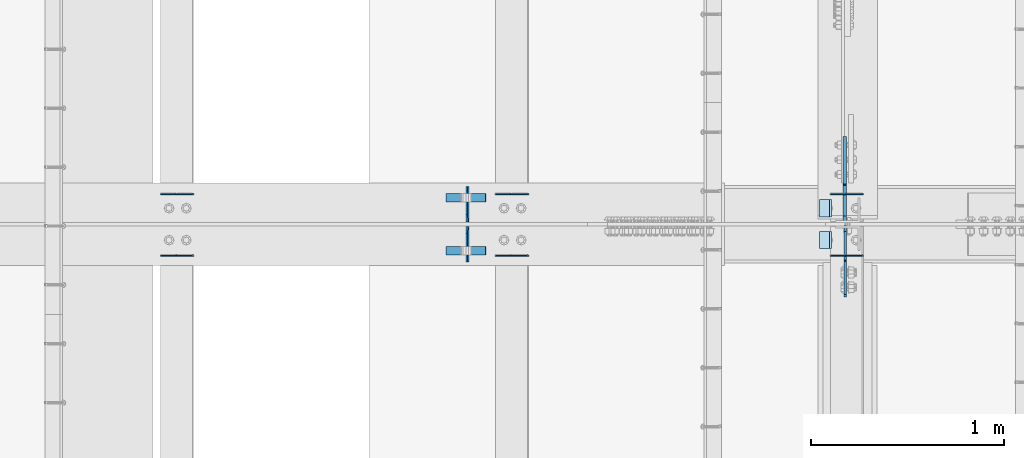
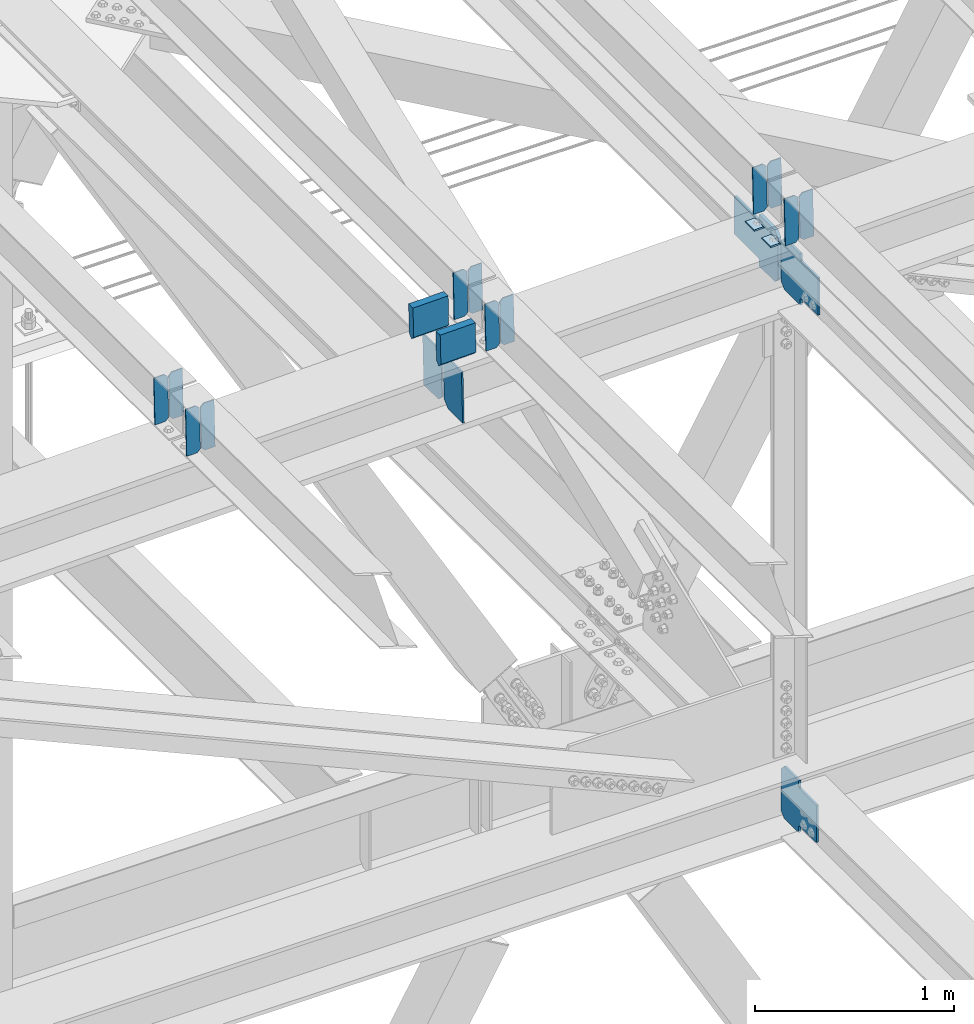
# One storey, part 3453 of 3843: 21 plates, 8 elements without a shape of their own.
"""IFC2X3 building model written with IfcOpenShell, lengths in millimetres."""

from ifc_helpers import new_model, si_unit, frame, origin_with_axes, place, context, subcontext, project, spatial, faceted_brep, material, type_object, element, aggregate, save


model = new_model("IFC2X3")

# Units and contexts
model_context = context("Model", 3, precision=1e-05, world=origin_with_axes())
body_context = subcontext(model_context, "Body", "Model", "MODEL_VIEW")
ifc_project = project(units=[si_unit("LENGTHUNIT", "METRE", prefix="MILLI"), si_unit("AREAUNIT", "SQUARE_METRE"), si_unit("VOLUMEUNIT", "CUBIC_METRE"), si_unit("MASSUNIT", "GRAM", prefix="KILO"), si_unit("TIMEUNIT", "SECOND"), si_unit("PLANEANGLEUNIT", "RADIAN"), si_unit("SOLIDANGLEUNIT", "STERADIAN"), si_unit("THERMODYNAMICTEMPERATUREUNIT", "DEGREE_CELSIUS"), si_unit("LUMINOUSINTENSITYUNIT", "LUMEN")], contexts=[model_context])

# Site, building, storey
site_placement = place(None, origin_with_axes())
site = spatial("IfcSite", under=ifc_project, at=site_placement, CompositionType="ELEMENT")
building_placement = place(site_placement, origin_with_axes())
building = spatial("IfcBuilding", under=site, at=building_placement, Name="Undefined", CompositionType="ELEMENT")
storey_placement = place(building_placement, origin_with_axes())
storey = spatial("IfcBuildingStorey", under=building, at=storey_placement, Name="Undefined", CompositionType="ELEMENT", Elevation=0.0)

# Assembly, plates
assembly_1_placement = place(storey_placement, origin_with_axes())
assembly_1 = element("IfcElementAssembly", 1, at=assembly_1_placement, inside=storey, Name="BEAM", AssemblyPlace="NOTDEFINED", PredefinedType="RIGID_FRAME")
ifc_material = material(Name="STEEL/A572-50")
plate_type_1 = type_object("IfcPlateType", PredefinedType="NOTDEFINED")
plate_1_placement = place(assembly_1_placement, frame((49078.8964783434, 84140.4727410739, 45699.8990310623), z_axis=(-0.0211520978682966, 0.000677816999712377, 0.999776039580808), x_axis=(-0.999776269350183, -1.43399999262055e-05, -0.021152093007418)))
plate_1 = element("IfcPlate", 2, at=plate_1_placement, type_object=plate_type_1, material=ifc_material, Name="PLATE", context=body_context, shape_type="Brep", body=[
    faceted_brep([(0.0, -3.17499999999927, 0.0), (6.83940015733242e-10, -3.17499999996653, 288.924999998613), (6.54836185276508e-10, 3.17500000001746, 288.924999998591), (0.0, 3.17499999999927, 0.0), (60.3250007643655, -3.17500000017753, 288.924999998606), (60.3250007643219, 3.17499999979918, 288.924999998584), (79.3750000013097, -3.17500000025029, 269.875000761494), (79.375000001266, 3.17499999972642, 269.875000761487), (79.375000000713, -3.17500000026484, 19.0499992370605), (79.3750000006985, 3.17499999971187, 19.0499992370533), (60.325000763667, -3.17500000020664, -1.45519152283669e-11), (60.3250007636234, 3.17499999977736, -3.63797880709171e-11)], [[[0, 1, 2, 3]], [[1, 4, 5, 2]], [[4, 6, 7, 5]], [[6, 8, 9, 7]], [[8, 10, 11, 9]], [[10, 0, 3, 11]], [[5, 7, 9, 11, 3, 2]], [[10, 8, 6, 4, 1, 0]]]),
])
plate_2_placement = place(assembly_1_placement, frame((48993.1906576538, 84140.4715117379, 45698.0857678784), z_axis=(-0.0211520978682966, 0.000677816999712377, 0.999776039580808), x_axis=(-0.999776269350183, -1.43399999262055e-05, -0.021152093007418)))
plate_2 = element("IfcPlate", 3, at=plate_2_placement, type_object=plate_type_1, material=ifc_material, Name="PLATE", context=body_context, shape_type="Brep", body=[
    faceted_brep([(4.36557456851006e-11, -3.17499999998836, 19.0499992370969), (6.11180439591408e-10, -3.17499999996653, 269.875000761516), (5.96628524363041e-10, 3.17500000001746, 269.875000761502), (1.45519152283669e-11, 3.17499999998836, 19.0499992370824), (19.0499992376572, -3.17500000003201, 288.924999998606), (19.0499992376281, 3.1749999999447, 288.924999998584), (79.3750000013242, -3.17500000025029, 288.924999998591), (79.3750000013097, 3.1749999997337, 288.92499999857), (79.3750000006548, -3.17500000026484, -2.18278728425503e-11), (79.3750000006403, 3.17499999969732, -2.91038304567337e-11), (19.0499992370023, -3.17500000005384, 0.0), (19.0499992369587, 3.17499999992287, -1.45519152283669e-11)], [[[0, 1, 2, 3]], [[1, 4, 5, 2]], [[4, 6, 7, 5]], [[6, 8, 9, 7]], [[8, 10, 11, 9]], [[10, 0, 3, 11]], [[5, 7, 9, 11, 3, 2]], [[10, 8, 6, 4, 1, 0]]]),
])

assembly_2_placement = place(storey_placement, origin_with_axes())
assembly_2 = element("IfcElementAssembly", 4, at=assembly_2_placement, inside=storey, Name="BEAM", AssemblyPlace="NOTDEFINED", PredefinedType="RIGID_FRAME")
plate_3_placement = place(assembly_2_placement, frame((49078.89647833, 83821.5416775285, 45700.9030193094), z_axis=(-0.0211520981352297, 0.00549190600185831, 0.999761185340251), x_axis=(-0.999776269344536, -0.000116190999951667, -0.0211517790073047)))
plate_3 = element("IfcPlate", 5, at=plate_3_placement, type_object=plate_type_1, material=ifc_material, Name="PLATE", context=body_context, shape_type="Brep", body=[
    faceted_brep([(0.0, -3.17499999999927, 0.0), (6.83940015733242e-10, -3.17499999996653, 288.924999998613), (6.54836185276508e-10, 3.17500000001746, 288.924999998591), (0.0, 3.17499999999927, 0.0), (60.3250007643655, -3.17500000017753, 288.924999998606), (60.3250007643219, 3.17499999979918, 288.924999998584), (79.3750000013097, -3.17500000025029, 269.875000761494), (79.375000001266, 3.17499999972642, 269.875000761487), (79.375000000713, -3.17500000026484, 19.0499992370605), (79.3750000006985, 3.17499999971187, 19.0499992370533), (60.325000763667, -3.17500000020664, -1.45519152283669e-11), (60.3250007636234, 3.17499999977736, -3.63797880709171e-11)], [[[0, 1, 2, 3]], [[1, 4, 5, 2]], [[4, 6, 7, 5]], [[6, 8, 9, 7]], [[8, 10, 11, 9]], [[10, 0, 3, 11]], [[5, 7, 9, 11, 3, 2]], [[10, 8, 6, 4, 1, 0]]]),
])
plate_4_placement = place(assembly_2_placement, frame((48993.1906576404, 83821.5317170273, 45699.0897830652), z_axis=(-0.0211520981352297, 0.00549190600185831, 0.999761185340251), x_axis=(-0.999776269344536, -0.000116190999951667, -0.0211517790073047)))
plate_4 = element("IfcPlate", 6, at=plate_4_placement, type_object=plate_type_1, material=ifc_material, Name="PLATE", context=body_context, shape_type="Brep", body=[
    faceted_brep([(4.36557456851006e-11, -3.17499999998836, 19.0499992370969), (6.11180439591408e-10, -3.17499999996653, 269.875000761516), (5.96628524363041e-10, 3.17500000001746, 269.875000761502), (1.45519152283669e-11, 3.17499999998836, 19.0499992370824), (19.0499992376572, -3.17500000003201, 288.924999998606), (19.0499992376281, 3.1749999999447, 288.924999998584), (79.3750000013242, -3.17500000025029, 288.924999998591), (79.3750000013097, 3.1749999997337, 288.92499999857), (79.3750000006548, -3.17500000026484, -2.18278728425503e-11), (79.3750000006403, 3.17499999969732, -2.91038304567337e-11), (19.0499992370023, -3.17500000005384, 0.0), (19.0499992369587, 3.17499999992287, -1.45519152283669e-11)], [[[0, 1, 2, 3]], [[1, 4, 5, 2]], [[4, 6, 7, 5]], [[6, 8, 9, 7]], [[8, 10, 11, 9]], [[10, 0, 3, 11]], [[5, 7, 9, 11, 3, 2]], [[10, 8, 6, 4, 1, 0]]]),
])

assembly_3_placement = place(storey_placement, origin_with_axes())
assembly_3 = element("IfcElementAssembly", 7, at=assembly_3_placement, inside=storey, Name="BEAM", AssemblyPlace="NOTDEFINED", PredefinedType="RIGID_FRAME")
plate_5_placement = place(assembly_3_placement, frame((47345.3464783848, 84140.5009790435, 45662.4008847744), z_axis=(-0.0211520976064639, 0.000583214000143924, 0.999776099248365), x_axis=(-0.999776269355723, -1.23390000258365e-05, -0.0211520940075068)))
plate_5 = element("IfcPlate", 8, at=plate_5_placement, type_object=plate_type_1, material=ifc_material, Name="PLATE", context=body_context, shape_type="Brep", body=[
    faceted_brep([(0.0, -3.17499999999927, 0.0), (6.83940015733242e-10, -3.17499999996653, 288.924999998613), (6.54836185276508e-10, 3.17500000001746, 288.924999998591), (0.0, 3.17499999999927, 0.0), (60.3250007643655, -3.17500000017753, 288.924999998606), (60.3250007643219, 3.17499999979918, 288.924999998584), (79.3750000013097, -3.17500000025029, 269.875000761494), (79.375000001266, 3.17499999972642, 269.875000761487), (79.375000000713, -3.17500000026484, 19.0499992370605), (79.3750000006985, 3.17499999971187, 19.0499992370533), (60.325000763667, -3.17500000020664, -1.45519152283669e-11), (60.3250007636234, 3.17499999977736, -3.63797880709171e-11)], [[[0, 1, 2, 3]], [[1, 4, 5, 2]], [[4, 6, 7, 5]], [[6, 8, 9, 7]], [[8, 10, 11, 9]], [[10, 0, 3, 11]], [[5, 7, 9, 11, 3, 2]], [[10, 8, 6, 4, 1, 0]]]),
])
plate_6_placement = place(assembly_3_placement, frame((47259.6406576955, 84140.4999212872, 45660.5876214818), z_axis=(-0.0211520976064639, 0.000583214000143924, 0.999776099248365), x_axis=(-0.999776269355723, -1.23390000258365e-05, -0.0211520940075068)))
plate_6 = element("IfcPlate", 9, at=plate_6_placement, type_object=plate_type_1, material=ifc_material, Name="PLATE", context=body_context, shape_type="Brep", body=[
    faceted_brep([(4.36557456851006e-11, -3.17499999998836, 19.0499992370969), (6.11180439591408e-10, -3.17499999996653, 269.875000761516), (5.96628524363041e-10, 3.17500000001746, 269.875000761502), (1.45519152283669e-11, 3.17499999998836, 19.0499992370824), (19.0499992376572, -3.17500000003201, 288.924999998606), (19.0499992376281, 3.1749999999447, 288.924999998584), (79.3750000013242, -3.17500000025029, 288.924999998591), (79.3750000013097, 3.1749999997337, 288.92499999857), (79.3750000006548, -3.17500000026484, -2.18278728425503e-11), (79.3750000006403, 3.17499999969732, -2.91038304567337e-11), (19.0499992370023, -3.17500000005384, 0.0), (19.0499992369587, 3.17499999992287, -1.45519152283669e-11)], [[[0, 1, 2, 3]], [[1, 4, 5, 2]], [[4, 6, 7, 5]], [[6, 8, 9, 7]], [[8, 10, 11, 9]], [[10, 0, 3, 11]], [[5, 7, 9, 11, 3, 2]], [[10, 8, 6, 4, 1, 0]]]),
])
aggregate(assembly_3, [plate_5, plate_6])

assembly_4_placement = place(storey_placement, origin_with_axes())
assembly_4 = element("IfcElementAssembly", 10, at=assembly_4_placement, inside=storey, Name="BEAM", AssemblyPlace="NOTDEFINED", PredefinedType="RIGID_FRAME")
plate_7_placement = place(assembly_4_placement, frame((47345.3464783197, 83821.7128468308, 45663.2949016812), z_axis=(-0.021152097592596, 0.00491481899929932, 0.999764188857371), x_axis=(-0.999776269348185, -0.000103241000061833, -0.0211518460074008)))
plate_7 = element("IfcPlate", 11, at=plate_7_placement, type_object=plate_type_1, material=ifc_material, Name="PLATE", context=body_context, shape_type="Brep", body=[
    faceted_brep([(0.0, -3.17499999999927, 0.0), (6.83940015733242e-10, -3.17499999996653, 288.924999998613), (6.54836185276508e-10, 3.17500000001746, 288.924999998591), (0.0, 3.17499999999927, 0.0), (60.3250007643655, -3.17500000017753, 288.924999998606), (60.3250007643219, 3.17499999979918, 288.924999998584), (79.3750000013097, -3.17500000025029, 269.875000761494), (79.375000001266, 3.17499999972642, 269.875000761487), (79.375000000713, -3.17500000026484, 19.0499992370605), (79.3750000006985, 3.17499999971187, 19.0499992370533), (60.325000763667, -3.17500000020664, -1.45519152283669e-11), (60.3250007636234, 3.17499999977736, -3.63797880709171e-11)], [[[0, 1, 2, 3]], [[1, 4, 5, 2]], [[4, 6, 7, 5]], [[6, 8, 9, 7]], [[8, 10, 11, 9]], [[10, 0, 3, 11]], [[5, 7, 9, 11, 3, 2]], [[10, 8, 6, 4, 1, 0]]]),
])
plate_8_placement = place(assembly_4_placement, frame((47259.6406576304, 83821.7039329758, 45661.4816599901), z_axis=(-0.021152097592596, 0.00491481899929932, 0.999764188857371), x_axis=(-0.999776269348185, -0.000103241000061833, -0.0211518460074008)))
plate_8 = element("IfcPlate", 12, at=plate_8_placement, type_object=plate_type_1, material=ifc_material, Name="PLATE", context=body_context, shape_type="Brep", body=[
    faceted_brep([(4.36557456851006e-11, -3.17499999998836, 19.0499992370969), (6.11180439591408e-10, -3.17499999996653, 269.875000761516), (5.96628524363041e-10, 3.17500000001746, 269.875000761502), (1.45519152283669e-11, 3.17499999998836, 19.0499992370824), (19.0499992376572, -3.17500000003201, 288.924999998606), (19.0499992376281, 3.1749999999447, 288.924999998584), (79.3750000013242, -3.17500000025029, 288.924999998591), (79.3750000013097, 3.1749999997337, 288.92499999857), (79.3750000006548, -3.17500000026484, -2.18278728425503e-11), (79.3750000006403, 3.17499999969732, -2.91038304567337e-11), (19.0499992370023, -3.17500000005384, 0.0), (19.0499992369587, 3.17499999992287, -1.45519152283669e-11)], [[[0, 1, 2, 3]], [[1, 4, 5, 2]], [[4, 6, 7, 5]], [[6, 8, 9, 7]], [[8, 10, 11, 9]], [[10, 0, 3, 11]], [[5, 7, 9, 11, 3, 2]], [[10, 8, 6, 4, 1, 0]]]),
])
aggregate(assembly_4, [plate_7, plate_8])

assembly_5_placement = place(storey_placement, origin_with_axes())
assembly_5 = element("IfcElementAssembly", 13, at=assembly_5_placement, inside=storey, Name="BEAM", AssemblyPlace="NOTDEFINED", PredefinedType="RIGID_FRAME")
plate_9_placement = place(assembly_5_placement, frame((45611.7964783437, 84140.5292142055, 45624.9027453821), z_axis=(-0.0211520975333623, 0.000488609999985782, 0.999776149960684), x_axis=(-0.999776269357269, -1.03370000525781e-05, -0.0211520950075214)))
plate_9 = element("IfcPlate", 14, at=plate_9_placement, type_object=plate_type_1, material=ifc_material, Name="PLATE", context=body_context, shape_type="Brep", body=[
    faceted_brep([(0.0, -3.17499999999927, 0.0), (6.83940015733242e-10, -3.17499999996653, 288.924999998613), (6.54836185276508e-10, 3.17500000001746, 288.924999998591), (0.0, 3.17499999999927, 0.0), (60.3250007643655, -3.17500000017753, 288.924999998606), (60.3250007643219, 3.17499999979918, 288.924999998584), (79.3750000013097, -3.17500000025029, 269.875000761494), (79.375000001266, 3.17499999972642, 269.875000761487), (79.375000000713, -3.17500000026484, 19.0499992370605), (79.3750000006985, 3.17499999971187, 19.0499992370533), (60.325000763667, -3.17500000020664, -1.45519152283669e-11), (60.3250007636234, 3.17499999977736, -3.63797880709171e-11)], [[[0, 1, 2, 3]], [[1, 4, 5, 2]], [[4, 6, 7, 5]], [[6, 8, 9, 7]], [[8, 10, 11, 9]], [[10, 0, 3, 11]], [[5, 7, 9, 11, 3, 2]], [[10, 8, 6, 4, 1, 0]]]),
])
plate_10_placement = place(assembly_5_placement, frame((45526.0906576544, 84140.5283280276, 45623.0894819972), z_axis=(-0.0211520975333623, 0.000488609999985782, 0.999776149960684), x_axis=(-0.999776269357269, -1.03370000525781e-05, -0.0211520950075214)))
plate_10 = element("IfcPlate", 15, at=plate_10_placement, type_object=plate_type_1, material=ifc_material, Name="PLATE", context=body_context, shape_type="Brep", body=[
    faceted_brep([(4.36557456851006e-11, -3.17499999998836, 19.0499992370969), (6.11180439591408e-10, -3.17499999996653, 269.875000761516), (5.96628524363041e-10, 3.17500000001746, 269.875000761502), (1.45519152283669e-11, 3.17499999998836, 19.0499992370824), (19.0499992376572, -3.17500000003201, 288.924999998606), (19.0499992376281, 3.1749999999447, 288.924999998584), (79.3750000013242, -3.17500000025029, 288.924999998591), (79.3750000013097, 3.1749999997337, 288.92499999857), (79.3750000006548, -3.17500000026484, -2.18278728425503e-11), (79.3750000006403, 3.17499999969732, -2.91038304567337e-11), (19.0499992370023, -3.17500000005384, 0.0), (19.0499992369587, 3.17499999992287, -1.45519152283669e-11)], [[[0, 1, 2, 3]], [[1, 4, 5, 2]], [[4, 6, 7, 5]], [[6, 8, 9, 7]], [[8, 10, 11, 9]], [[10, 0, 3, 11]], [[5, 7, 9, 11, 3, 2]], [[10, 8, 6, 4, 1, 0]]]),
])
aggregate(assembly_5, [plate_9, plate_10])

assembly_6_placement = place(storey_placement, origin_with_axes())
assembly_6 = element("IfcElementAssembly", 16, at=assembly_6_placement, inside=storey, Name="BEAM", AssemblyPlace="NOTDEFINED", PredefinedType="RIGID_FRAME")
plate_11_placement = place(assembly_6_placement, frame((45611.7964783338, 83821.9023740224, 45625.6768602553), z_axis=(-0.0211520984919553, 0.00427626500010956, 0.999767124027909), x_axis=(-0.999776269336989, -9.04719999769659e-05, -0.0211519050071284)))
plate_11 = element("IfcPlate", 17, at=plate_11_placement, type_object=plate_type_1, material=ifc_material, Name="PLATE", context=body_context, shape_type="Brep", body=[
    faceted_brep([(0.0, -3.17499999999927, 0.0), (6.83940015733242e-10, -3.17499999996653, 288.924999998613), (6.54836185276508e-10, 3.17500000001746, 288.924999998591), (0.0, 3.17499999999927, 0.0), (60.3250007643655, -3.17500000017753, 288.924999998606), (60.3250007643219, 3.17499999979918, 288.924999998584), (79.3750000013097, -3.17500000025029, 269.875000761494), (79.375000001266, 3.17499999972642, 269.875000761487), (79.375000000713, -3.17500000026484, 19.0499992370605), (79.3750000006985, 3.17499999971187, 19.0499992370533), (60.325000763667, -3.17500000020664, -1.45519152283669e-11), (60.3250007636234, 3.17499999977736, -3.63797880709171e-11)], [[[0, 1, 2, 3]], [[1, 4, 5, 2]], [[4, 6, 7, 5]], [[6, 8, 9, 7]], [[8, 10, 11, 9]], [[10, 0, 3, 11]], [[5, 7, 9, 11, 3, 2]], [[10, 8, 6, 4, 1, 0]]]),
])
plate_12_placement = place(assembly_6_placement, frame((45526.0906576445, 83821.8946182921, 45623.8636132405), z_axis=(-0.0211520984919553, 0.00427626500010956, 0.999767124027909), x_axis=(-0.999776269336989, -9.04719999769659e-05, -0.0211519050071284)))
plate_12 = element("IfcPlate", 18, at=plate_12_placement, type_object=plate_type_1, material=ifc_material, Name="PLATE", context=body_context, shape_type="Brep", body=[
    faceted_brep([(4.36557456851006e-11, -3.17499999998836, 19.0499992370969), (6.11180439591408e-10, -3.17499999996653, 269.875000761516), (5.96628524363041e-10, 3.17500000001746, 269.875000761502), (1.45519152283669e-11, 3.17499999998836, 19.0499992370824), (19.0499992376572, -3.17500000003201, 288.924999998606), (19.0499992376281, 3.1749999999447, 288.924999998584), (79.3750000013242, -3.17500000025029, 288.924999998591), (79.3750000013097, 3.1749999997337, 288.92499999857), (79.3750000006548, -3.17500000026484, -2.18278728425503e-11), (79.3750000006403, 3.17499999969732, -2.91038304567337e-11), (19.0499992370023, -3.17500000005384, 0.0), (19.0499992369587, 3.17499999992287, -1.45519152283669e-11)], [[[0, 1, 2, 3]], [[1, 4, 5, 2]], [[4, 6, 7, 5]], [[6, 8, 9, 7]], [[8, 10, 11, 9]], [[10, 0, 3, 11]], [[5, 7, 9, 11, 3, 2]], [[10, 8, 6, 4, 1, 0]]]),
])
aggregate(assembly_6, [plate_11, plate_12])

assembly_7_placement = place(storey_placement, origin_with_axes())
assembly_7 = element("IfcElementAssembly", 19, at=assembly_7_placement, inside=storey, Name="BEAM", AssemblyPlace="NOTDEFINED", PredefinedType="RIGID_FRAME")
plate_type_2 = type_object("IfcPlateType", PredefinedType="NOTDEFINED")
plate_13_placement = place(assembly_7_placement, frame((47032.4197010453, 83789.8375, 45288.9614881517), z_axis=(-0.0216342480057937, 0.0, 0.999765952267441), x_axis=(0.0, 1.0, 0.0)))
plate_13 = element("IfcPlate", 20, at=plate_13_placement, type_object=plate_type_2, material=ifc_material, Name="PL", context=body_context, shape_type="Brep", body=[
    faceted_brep([(0.0, -4.76249999999709, 0.0), (0.0, -4.76249999785796, 317.500000005042), (0.0, 4.76250000210712, 317.50000000505), (0.0, 4.76249999999709, 0.0), (146.050001525873, -4.76249999785796, 317.500000005042), (146.050001525873, 4.76250000210712, 317.50000000505), (184.149999999994, -4.76249999810534, 279.400001530797), (184.149999999994, 4.76250000185973, 279.400001530805), (184.149999999994, -4.7624999997206, 38.0999984742448), (184.149999999994, 4.76250000022992, 38.0999984742448), (146.049999999988, -4.76250000000073, 0.0), (146.049999999988, 4.76250000000073, 0.0)], [[[0, 1, 2, 3]], [[1, 4, 5, 2]], [[4, 6, 7, 5]], [[6, 8, 9, 7]], [[8, 10, 11, 9]], [[10, 0, 3, 11]], [[5, 7, 9, 11, 3, 2]], [[10, 8, 6, 4, 1, 0]]]),
])
plate_14_placement = place(assembly_7_placement, frame((47032.4197010453, 83996.2125, 45288.9614881517), z_axis=(-0.0216342480057937, 0.0, 0.999765952267441), x_axis=(0.0, 1.0, 0.0)))
plate_14 = element("IfcPlate", 21, at=plate_14_placement, type_object=plate_type_2, material=ifc_material, Name="PL", context=body_context, shape_type="Brep", body=[
    faceted_brep([(0.0, -4.76250000000073, 38.0999999999985), (0.0, -4.76249999810534, 279.400001530797), (0.0, 4.76250000185973, 279.400001530805), (0.0, 4.76250000000073, 38.0999999999985), (38.0999984741211, -4.76249999785796, 317.500000005042), (38.0999984741211, 4.76250000210712, 317.50000000505), (184.150000000009, -4.76249999999709, 317.5), (184.150000000009, 4.76249999999709, 317.5), (184.150000000009, -4.76249999999709, 0.0), (184.150000000009, 4.76249999999709, 0.0), (38.0999984741211, -4.76249999996799, 0.0), (38.0999984741211, 4.76249999998254, 0.0)], [[[0, 1, 2, 3]], [[1, 4, 5, 2]], [[4, 6, 7, 5]], [[6, 8, 9, 7]], [[8, 10, 11, 9]], [[10, 0, 3, 11]], [[5, 7, 9, 11, 3, 2]], [[10, 8, 6, 4, 1, 0]]]),
])
plate_type_3 = type_object("IfcPlateType", PredefinedType="NOTDEFINED")
plate_15_placement = place(assembly_7_placement, frame((46918.6842008661, 84121.228125, 45845.3272449958), z_axis=(0.0217666070074993, 0.0, -0.999763079343992), x_axis=(0.999763079343992, 0.0, 0.0217666070075027)))
plate_15 = element("IfcPlate", 22, at=plate_15_placement, type_object=plate_type_3, material=ifc_material, Name="PLATE", context=body_context, shape_type="Brep", body=[
    faceted_brep([(203.200005058941, -22.2250000000058, -1.16415321826935e-10), (7.27595761418343e-12, -22.2250000000058, -7.27595761418343e-12), (7.27595761418343e-12, 22.2250000000058, -7.27595761418343e-12), (203.200005058941, 22.2250000000058, -1.16415321826935e-10), (203.838531807472, -22.2250000000058, 0.00187068080413155), (203.838531807472, 22.2250000000058, 0.00187068080413155), (203.310341304641, -22.2250000000058, 180.861817383484), (0.04046799018397, -22.2250000000058, 180.907287948779), (203.245434494536, 0.0133131837355904, 203.086833080139), (0.0454396034692763, 0.0133129994646879, 203.132287829787), (0.0404679902494536, 22.2250000000058, 180.907288225317), (203.310341303353, 22.2250000000058, 180.861817822159)], [[[0, 1, 2, 3]], [[4, 0, 3, 5]], [[1, 0, 4, 6, 7]], [[7, 6, 8, 9]], [[2, 1, 7, 9, 10]], [[5, 3, 2, 10, 11]], [[6, 4, 5, 11, 8]], [[10, 9, 8, 11]]]),
])
plate_16_placement = place(assembly_7_placement, frame((46918.6842008661, 83848.178125, 45845.3272449958), z_axis=(0.0217666070074993, 0.0, -0.999763079343992), x_axis=(0.999763079343992, 0.0, 0.0217666070075027)))
plate_16 = element("IfcPlate", 23, at=plate_16_placement, type_object=plate_type_3, material=ifc_material, Name="PLATE", context=body_context, shape_type="Brep", body=[
    faceted_brep([(203.200005058941, -22.2250000000058, -1.16415321826935e-10), (7.27595761418343e-12, -22.2250000000058, -7.27595761418343e-12), (7.27595761418343e-12, 22.2250000000058, -7.27595761418343e-12), (203.200005058941, 22.2250000000058, -1.16415321826935e-10), (203.838531807472, -22.2250000000058, 0.00187068080413155), (203.838531807472, 22.2250000000058, 0.00187068080413155), (203.310341304641, -22.2250000000058, 180.861817383484), (0.04046799018397, -22.2250000000058, 180.907287948779), (203.245434494536, 0.0133131837355904, 203.086833080139), (0.0454396034692763, 0.0133129994646879, 203.132287829787), (0.0404679902494536, 22.2250000000058, 180.907288225317), (203.310341303353, 22.2250000000058, 180.861817822159)], [[[0, 1, 2, 3]], [[4, 0, 3, 5]], [[1, 0, 4, 6, 7]], [[7, 6, 8, 9]], [[2, 1, 7, 9, 10]], [[5, 3, 2, 10, 11]], [[6, 4, 5, 11, 8]], [[10, 9, 8, 11]]]),
])

# Plate
plate_type_4 = type_object("IfcPlateType", PredefinedType="NOTDEFINED")
plate_17_placement = place(assembly_1_placement, frame((48913.9677313287, 84112.0999999999, 45690.1636114864), z_axis=(0.0, -1.0, 0.0), x_axis=(-0.999776270257024, 0.0, -0.0211520550054595)))
plate_17 = element("IfcPlate", 24, at=plate_17_placement, type_object=plate_type_4, material=ifc_material, Name="PLATE", context=body_context, shape_type="Brep", body=[
    faceted_brep([(9.52499999982683, -4.7625000001135, 88.8999999999942), (0.0, 4.76249999999709, 88.9000015258789), (0.0, 4.76249999999709, 0.0), (9.52499999981956, -4.76249999999709, 0.0), (63.4999984608512, -4.76249999988795, 88.8999999999796), (63.4999984608367, -4.76249999988795, -1.45519152283669e-11), (63.4999984608221, 4.76250000013533, -1.45519152283669e-11), (63.4999984608367, 4.76250000013533, 88.8999999999796)], [[[0, 1, 2, 3]], [[4, 5, 6, 7]], [[5, 4, 0, 3]], [[6, 5, 3, 2]], [[7, 6, 2, 1]], [[4, 7, 1, 0]]]),
])

aggregate(assembly_1, [plate_1, plate_2, plate_17])

plate_18_placement = place(assembly_2_placement, frame((48913.9677313287, 83947.0000015258, 45690.1636114864), z_axis=(0.0, -1.0, 0.0), x_axis=(-0.999776270257024, 0.0, -0.0211520550054595)))
plate_18 = element("IfcPlate", 25, at=plate_18_placement, type_object=plate_type_4, material=ifc_material, Name="PLATE", context=body_context, shape_type="Brep", body=[
    faceted_brep([(9.52499999982683, -4.7625000001135, 88.8999999999942), (0.0, 4.76249999999709, 88.9000015258789), (0.0, 4.76249999999709, 0.0), (9.52499999981956, -4.76249999999709, 0.0), (63.4999984608512, -4.76249999988795, 88.8999999999796), (63.4999984608367, -4.76249999988795, -1.45519152283669e-11), (63.4999984608221, 4.76250000013533, -1.45519152283669e-11), (63.4999984608367, 4.76250000013533, 88.8999999999796)], [[[0, 1, 2, 3]], [[4, 5, 6, 7]], [[5, 4, 0, 3]], [[6, 5, 3, 2]], [[7, 6, 2, 1]], [[4, 7, 1, 0]]]),
])

aggregate(assembly_2, [plate_3, plate_4, plate_18])

# Assembly, plate
assembly_8_placement = place(storey_placement, origin_with_axes())
assembly_8 = element("IfcElementAssembly", 26, at=assembly_8_placement, inside=storey, Name="BEAM", AssemblyPlace="NOTDEFINED", PredefinedType="RIGID_FRAME")
plate_type_5 = type_object("IfcPlateType", PredefinedType="NOTDEFINED")
plate_19_placement = place(assembly_8_placement, frame((48985.4874999891, 83977.9562499989, 42125.5445343983), z_axis=(0.0, -0.707106781186682, 0.707106781186413), x_axis=(0.0, -0.707106781186548, -0.707106781186548)))
plate_19 = element("IfcPlate", 27, at=plate_19_placement, type_object=plate_type_5, material=ifc_material, Name="PLATE", context=body_context, shape_type="Brep", body=[
    faceted_brep([(0.0, -6.3499999046162, 0.0), (-179.600813047069, -6.35000000000582, 179.600813047073), (-179.600813047069, 6.35000000000582, 179.600813047073), (7.27595761418343e-12, 6.3499999046162, 0.0), (-179.600813047073, -6.35000000000582, 224.502093652191), (-179.600813047073, 6.35000000000582, 224.502093652191), (-75.7666016477051, -6.35000000000582, 328.336305051562), (-75.7666016477051, 6.35000000000582, 328.336305051562), (-54.2654183481573, -6.34999999999854, 306.835121764823), (-54.2654183481573, 6.34999999999854, 306.835121764823), (-50.1452418800109, -6.34999999999854, 304.082107864357), (-50.1452418800109, 6.34999999999854, 304.082107864357), (-45.285162361979, -6.34999999999854, 303.115377941765), (-45.285162361979, 6.34999999999854, 303.115377941765), (-40.4250828439472, -6.34999999999854, 304.082107864357), (-40.4250828439472, 6.34999999999854, 304.082107864357), (-36.3049063758008, -6.34999999999854, 306.835121764823), (-36.3049063758008, 6.34999999999854, 306.835121764823), (80.4384233285746, -6.34999999999854, 423.578451469206), (80.4384233285746, 6.34999999999854, 423.578451469206), (242.083033507046, -6.34999999999854, 261.933841290738), (242.083033507046, 6.34999999999854, 261.933841290738), (125.339703802671, -6.34999999999854, 145.190511586348), (125.339703802671, 6.34999999999854, 145.190511586348), (122.5866899022, -6.34999999999854, 141.070335118209), (122.5866899022, 6.34999999999854, 141.070335118209), (121.619959979613, -6.34999999999854, 136.210255600177), (121.619959979613, 6.34999999999854, 136.210255600177), (122.5866899022, -6.34999999999854, 131.350176082145), (122.5866899022, 6.34999999999854, 131.350176082145), (125.339703802671, -6.34999999999854, 127.229999614006), (125.339703802671, 6.34999999999854, 127.229999614006), (148.735492004496, -6.35000000000582, 103.834211399357), (148.735492004496, 6.35000000000582, 103.834211399357), (44.9012806051323, -6.35000000000582, -1.45519152283669e-11), (44.9012806051323, 6.35000000000582, -1.45519152283669e-11)], [[[0, 1, 2, 3]], [[1, 4, 5, 2]], [[4, 6, 7, 5]], [[6, 8, 9, 7]], [[8, 10, 11, 9]], [[10, 12, 13, 11]], [[12, 14, 15, 13]], [[14, 16, 17, 15]], [[16, 18, 19, 17]], [[18, 20, 21, 19]], [[20, 22, 23, 21]], [[22, 24, 25, 23]], [[24, 26, 27, 25]], [[26, 28, 29, 27]], [[28, 30, 31, 29]], [[30, 32, 33, 31]], [[32, 34, 35, 33]], [[34, 0, 3, 35]], [[5, 7, 9, 11, 13, 15, 17, 19, 21, 23, 25, 27, 29, 31, 33, 35, 3, 2]], [[34, 32, 30, 28, 26, 24, 22, 20, 18, 16, 14, 12, 10, 8, 6, 4, 1, 0]]]),
])
aggregate(assembly_8, [plate_19])

# Plate
plate_20_placement = place(assembly_7_placement, frame((48985.4874999877, 83973.9875000011, 45363.1115707237), z_axis=(0.0, -0.707106781186682, 0.707106781186413), x_axis=(0.0, -0.707106781186548, -0.707106781186548)))
plate_20 = element("IfcPlate", 28, at=plate_20_placement, type_object=plate_type_5, material=ifc_material, Name="PLATE", context=body_context, shape_type="Brep", body=[
    faceted_brep([(0.0, -6.3499999046162, 0.0), (-179.46387894213, -6.35000000000582, 179.46387894213), (-179.46387894213, 6.35000000000582, 179.46387894213), (7.27595761418343e-12, 6.3499999046162, 0.0), (-179.463878941897, -6.35000000000582, 224.365159547495), (-179.463878941897, 6.35000000000582, 224.365159547495), (-68.3332094431244, -6.35000000000582, 335.495829046271), (-68.3332094431244, 6.35000000000582, 335.495829046271), (-47.1219202674256, -6.34999999999854, 314.284539969769), (-47.1219202674256, 6.34999999999854, 314.284539969769), (-43.0017437992647, -6.34999999999854, 311.53152606931), (-43.0017437992647, 6.34999999999854, 311.53152606931), (-38.141664281211, -6.34999999999854, 310.564796146748), (-38.141664281211, 6.34999999999854, 310.564796146748), (-33.2815847631573, -6.34999999999854, 311.531526069353), (-33.2815847631573, 6.34999999999854, 311.531526069353), (-29.1614082949673, -6.34999999999854, 314.28453996986), (-29.1614082949673, 6.34999999999854, 314.28453996986), (87.5819213675713, -6.34999999999854, 431.027869632377), (87.5819213675713, 6.34999999999854, 431.027869632377), (249.226531546024, -6.34999999999854, 269.383259453894), (249.226531546024, 6.34999999999854, 269.383259453894), (132.483201883486, -6.34999999999854, 152.63992979137), (132.483201883486, 6.34999999999854, 152.63992979137), (129.730187982976, -6.34999999999854, 148.519753323191), (129.730187982976, 6.34999999999854, 148.519753323191), (128.763458060363, -6.34999999999854, 143.659673805138), (128.763458060363, 6.34999999999854, 143.659673805138), (129.730187982917, -6.34999999999854, 138.799594287077), (129.730187982917, 6.34999999999854, 138.799594287077), (132.483201883399, -6.34999999999854, 134.67941781893), (132.483201883399, 6.34999999999854, 134.67941781893), (156.031950102829, -6.35000000000582, 111.130669497703), (156.031950102829, 6.35000000000582, 111.130669497703), (44.9012806051323, -6.35000000000582, -1.45519152283669e-11), (44.9012806051323, 6.35000000000582, -1.45519152283669e-11)], [[[0, 1, 2, 3]], [[1, 4, 5, 2]], [[4, 6, 7, 5]], [[6, 8, 9, 7]], [[8, 10, 11, 9]], [[10, 12, 13, 11]], [[12, 14, 15, 13]], [[14, 16, 17, 15]], [[16, 18, 19, 17]], [[18, 20, 21, 19]], [[20, 22, 23, 21]], [[22, 24, 25, 23]], [[24, 26, 27, 25]], [[26, 28, 29, 27]], [[28, 30, 31, 29]], [[30, 32, 33, 31]], [[32, 34, 35, 33]], [[34, 0, 3, 35]], [[5, 7, 9, 11, 13, 15, 17, 19, 21, 23, 25, 27, 29, 31, 33, 35, 3, 2]], [[34, 32, 30, 28, 26, 24, 22, 20, 18, 16, 14, 12, 10, 8, 6, 4, 1, 0]]]),
])

plate_type_6 = type_object("IfcPlateType", PredefinedType="NOTDEFINED")
plate_21_placement = place(assembly_7_placement, frame((48982.3124997347, 83996.2125, 45363.1115708058), z_axis=(0.0, 0.707106781186548, 0.707106781186548), x_axis=(5.70000238222118e-08, 0.707106781186546, -0.707106781186546)))
plate_21 = element("IfcPlate", 29, at=plate_21_placement, type_object=plate_type_6, material=ifc_material, Name="PLATE", context=body_context, shape_type="Brep", body=[
    faceted_brep([(0.0, -9.52500000000146, 0.0), (-179.366715657274, -9.52499999999418, 179.366715657248), (-179.366715657274, 9.52499999999418, 179.366715657248), (0.0, 9.52500000000146, 0.0), (-179.366715656826, -9.52499999999418, 224.267996262832), (-179.366715656826, 9.52499999999418, 224.267996262832), (-68.2360461568533, -9.52499999999418, 335.398665762827), (-68.2360461568533, 9.52499999999418, 335.398665762827), (-46.1232264977771, -9.52499999999418, 313.285846103783), (-46.1232264977771, 9.52499999999418, 313.285846103783), (-42.003050029638, -9.52499999999418, 310.532832203317), (-42.003050029638, 9.52499999999418, 310.532832203317), (-37.1429705115806, -9.52499999999418, 309.566102280762), (-37.1429705115806, 9.52499999999418, 309.566102280762), (-32.2828909935233, -9.52499999999418, 310.53283220336), (-32.2828909935233, 9.52499999999418, 310.53283220336), (-28.1627145253442, -9.52499999999418, 313.28584610387), (-28.1627145253442, 9.52499999999418, 313.28584610387), (142.462151912587, -9.52499999999418, 483.910712541838), (142.462151912587, 9.52499999999418, 483.910712541838), (304.106762091076, -9.52499999999418, 322.266102363385), (304.106762091076, 9.52499999999418, 322.266102363385), (133.481895653153, -9.52499999999418, 151.641235925432), (133.481895653153, 9.52499999999418, 151.641235925432), (130.728881752639, -9.52499999999418, 147.521059457242), (130.728881752639, 9.52499999999418, 147.521059457242), (129.762151830029, -9.52499999999418, 142.660979939188), (129.762151830029, 9.52499999999418, 142.660979939188), (130.728881752595, -9.52499999999418, 137.80090042112), (130.728881752595, 9.52499999999418, 137.80090042112), (133.481895653069, -9.52499999999418, 133.680723952973), (133.481895653069, 9.52499999999418, 133.680723952973), (156.031950102854, -9.52499999999418, 111.130669497732), (156.031950102854, 9.52499999999418, 111.130669497732), (44.9012806055835, -9.52499999999418, 4.65661287307739e-10), (44.9012806055835, 9.52499999999418, 4.65661287307739e-10)], [[[0, 1, 2, 3]], [[1, 4, 5, 2]], [[4, 6, 7, 5]], [[6, 8, 9, 7]], [[8, 10, 11, 9]], [[10, 12, 13, 11]], [[12, 14, 15, 13]], [[14, 16, 17, 15]], [[16, 18, 19, 17]], [[18, 20, 21, 19]], [[20, 22, 23, 21]], [[22, 24, 25, 23]], [[24, 26, 27, 25]], [[26, 28, 29, 27]], [[28, 30, 31, 29]], [[30, 32, 33, 31]], [[32, 34, 35, 33]], [[34, 0, 3, 35]], [[5, 7, 9, 11, 13, 15, 17, 19, 21, 23, 25, 27, 29, 31, 33, 35, 3, 2]], [[34, 32, 30, 28, 26, 24, 22, 20, 18, 16, 14, 12, 10, 8, 6, 4, 1, 0]]]),
])

aggregate(assembly_7, [plate_13, plate_14, plate_15, plate_16, plate_21, plate_20])

save(model, "model.ifc")
